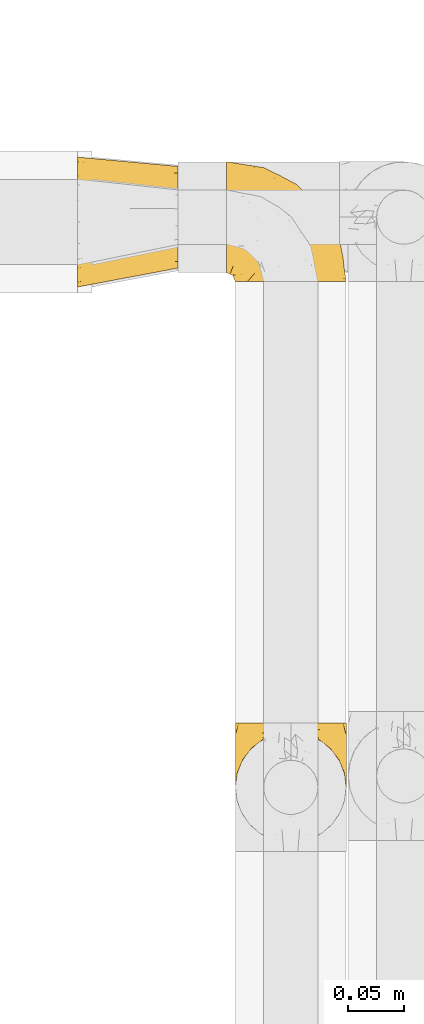
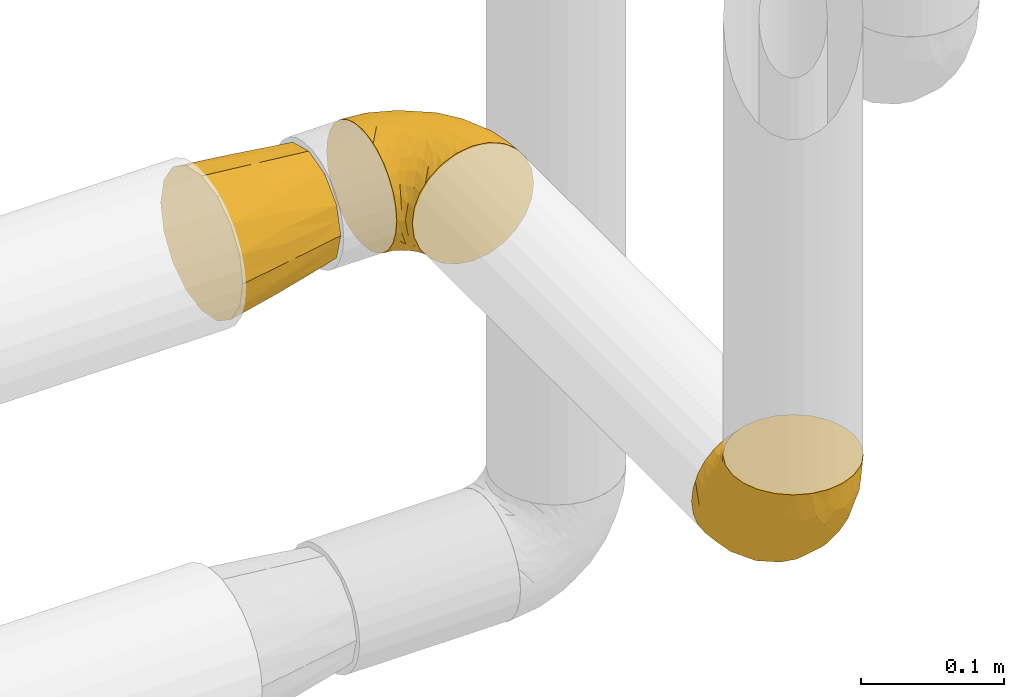
# One storey, part 415 of 824: 3 coverings.
"""IFC2X3 building model written with IfcOpenShell, lengths in millimetres."""

from ifc_helpers import new_model, entity, si_unit, converted_unit, derived_unit, direction, frame, origin, place, context, subcontext, project, spatial, faceted_brep, element, save


model = new_model("IFC2X3")

# Units and contexts
model_context = context("Model", 3, precision=0.01, world=origin(), true_north=direction((6.12303176911189e-17, 1.0)))
body_context = subcontext(model_context, "Body", "Model", "MODEL_VIEW")
ifc_project = project(units=[si_unit("LENGTHUNIT", "METRE", prefix="MILLI"), si_unit("AREAUNIT", "SQUARE_METRE"), si_unit("VOLUMEUNIT", "CUBIC_METRE"), converted_unit("PLANEANGLEUNIT", "DEGREE", entity("IfcRatioMeasure", 0.0174532925199433), si_unit("PLANEANGLEUNIT", "RADIAN"), dimensions=[0, 0, 0, 0, 0, 0, 0]), si_unit("MASSUNIT", "GRAM", prefix="KILO"), derived_unit("MASSDENSITYUNIT", [(si_unit("MASSUNIT", "GRAM", prefix="KILO"), 1), (si_unit("LENGTHUNIT", "METRE"), -3)]), derived_unit("MOMENTOFINERTIAUNIT", [(si_unit("LENGTHUNIT", "METRE"), 4)]), si_unit("TIMEUNIT", "SECOND"), si_unit("FREQUENCYUNIT", "HERTZ"), si_unit("THERMODYNAMICTEMPERATUREUNIT", "DEGREE_CELSIUS"), derived_unit("THERMALTRANSMITTANCEUNIT", [(si_unit("MASSUNIT", "GRAM", prefix="KILO"), 1), (si_unit("THERMODYNAMICTEMPERATUREUNIT", "KELVIN"), -1), (si_unit("TIMEUNIT", "SECOND"), -3)]), derived_unit("VOLUMETRICFLOWRATEUNIT", [(si_unit("LENGTHUNIT", "METRE"), 3), (si_unit("TIMEUNIT", "SECOND"), -1)]), derived_unit("MASSFLOWRATEUNIT", [(si_unit("MASSUNIT", "GRAM", prefix="KILO"), 1), (si_unit("TIMEUNIT", "SECOND"), -1)]), derived_unit("ROTATIONALFREQUENCYUNIT", [(si_unit("TIMEUNIT", "SECOND"), -1)]), si_unit("ELECTRICCURRENTUNIT", "AMPERE"), si_unit("ELECTRICVOLTAGEUNIT", "VOLT"), si_unit("POWERUNIT", "WATT"), si_unit("FORCEUNIT", "NEWTON", prefix="KILO"), si_unit("ILLUMINANCEUNIT", "LUX"), si_unit("LUMINOUSFLUXUNIT", "LUMEN"), si_unit("LUMINOUSINTENSITYUNIT", "CANDELA"), derived_unit("USERDEFINED", [(si_unit("MASSUNIT", "GRAM", prefix="KILO"), -1), (si_unit("LENGTHUNIT", "METRE"), -2), (si_unit("TIMEUNIT", "SECOND"), 3), (si_unit("LUMINOUSFLUXUNIT", "LUMEN"), 1)]), derived_unit("LINEARVELOCITYUNIT", [(si_unit("LENGTHUNIT", "METRE"), 1), (si_unit("TIMEUNIT", "SECOND"), -1)]), si_unit("PRESSUREUNIT", "PASCAL"), derived_unit("USERDEFINED", [(si_unit("LENGTHUNIT", "METRE"), -2), (si_unit("MASSUNIT", "GRAM", prefix="KILO"), 1), (si_unit("TIMEUNIT", "SECOND"), -2)]), derived_unit("LINEARFORCEUNIT", [(si_unit("MASSUNIT", "GRAM", prefix="KILO"), 1), (si_unit("LENGTHUNIT", "METRE"), 1), (si_unit("TIMEUNIT", "SECOND"), -2), (si_unit("LENGTHUNIT", "METRE"), -1)]), derived_unit("PLANARFORCEUNIT", [(si_unit("MASSUNIT", "GRAM", prefix="KILO"), 1), (si_unit("LENGTHUNIT", "METRE"), 1), (si_unit("TIMEUNIT", "SECOND"), -2), (si_unit("LENGTHUNIT", "METRE"), -2)])], contexts=[model_context])

# Site, building, storey
site_placement = place(None, origin())
site = spatial("IfcSite", under=ifc_project, at=site_placement, CompositionType="ELEMENT")
building_placement = place(site_placement, origin())
building = spatial("IfcBuilding", under=site, at=building_placement, CompositionType="ELEMENT")
storey_placement = place(building_placement, frame((0.0, 0.0, 28200.0)))
storey = spatial("IfcBuildingStorey", under=building, at=storey_placement, CompositionType="ELEMENT", Elevation=28200.0)

# Coverings
covering_1_placement = place(storey_placement, frame((50221.29, 18589.78, 1599.25)))
element("IfcCovering", 1, at=covering_1_placement, inside=storey, PredefinedType="INSULATION", context=body_context, shape_type="Brep", body=[
    faceted_brep([(99.9, 107.75, 50.75), (98.66, 107.75, 39.8), (95.02, 107.75, 29.41), (89.17, 107.75, 20.09), (81.38, 107.75, 12.31), (72.06, 107.75, 6.46), (61.68, 107.75, 2.83), (50.75, 107.75, 1.6), (39.8, 107.75, 2.83), (29.41, 107.75, 6.47), (20.09, 107.75, 12.32), (12.31, 107.75, 20.11), (6.46, 107.75, 29.43), (2.83, 107.75, 39.81), (1.6, 107.75, 50.75), (2.24, 107.75, 56.45), (2.83, 107.75, 61.69), (4.65, 107.75, 66.88), (6.47, 107.75, 72.08), (12.32, 107.75, 81.4), (20.11, 107.75, 89.18), (29.43, 107.75, 95.03), (39.81, 107.75, 98.66), (50.75, 107.75, 99.9), (61.69, 107.75, 98.66), (72.08, 107.75, 95.02), (81.4, 107.75, 89.17), (89.18, 107.75, 81.38), (95.03, 107.75, 72.06), (96.85, 107.75, 66.87), (98.66, 107.75, 61.68), (99.25, 107.75, 56.45), (99.57, 107.75, 53.6), (38.02, 98.22, 107.75), (26.17, 93.31, 107.75), (21.08, 89.4, 107.75), (15.99, 85.5, 107.75), (12.09, 80.41, 107.75), (8.18, 75.32, 107.75), (5.73, 69.39, 107.75), (3.27, 63.47, 107.75), (2.35, 56.48, 107.75), (1.97, 53.61, 107.75), (1.6, 50.75, 107.75), (3.27, 38.02, 107.75), (8.18, 26.17, 107.75), (15.99, 15.99, 107.75), (26.17, 8.18, 107.75), (38.02, 3.27, 107.75), (50.75, 1.6, 107.75), (63.47, 3.27, 107.75), (75.32, 8.18, 107.75), (85.5, 15.99, 107.75), (93.31, 26.17, 107.75), (98.22, 38.02, 107.75), (99.9, 50.75, 107.75), (99.14, 56.48, 107.75), (98.22, 63.47, 107.75), (95.77, 69.39, 107.75), (93.31, 75.32, 107.75), (89.4, 80.41, 107.75), (85.5, 85.5, 107.75), (80.41, 89.4, 107.75), (75.32, 93.31, 107.75), (63.47, 98.22, 107.75), (50.75, 99.9, 107.75), (59.31, 27.53, 39.38), (73.08, 25.32, 49.75), (63.72, 16.29, 57.38), (50.75, 6.79, 74.94), (58.64, 4.51, 85.97), (50.75, 3.51, 95.66), (76.74, 17.47, 67.82), (67.68, 7.6, 83.09), (78.92, 12.27, 89.16), (94.31, 70.89, 37.01), (98.76, 87.17, 43.46), (98.4, 67.3, 51.79), (94.57, 31.65, 85.58), (89.91, 33.58, 62.84), (96.32, 47.23, 62.77), (98.79, 43.26, 88.17), (99.9, 55.08, 85.93), (99.9, 53.99, 91.42), (99.9, 52.9, 96.91), (99.9, 52.36, 99.62), (99.9, 51.82, 102.33), (87.31, 21.5, 82.57), (95.61, 89.94, 32.75), (60.43, 60.45, 13.79), (65.24, 83.0, 6.77), (72.87, 64.79, 16.46), (99.9, 85.93, 55.08), (99.9, 81.31, 58.17), (99.9, 76.69, 61.26), (99.9, 72.06, 64.35), (99.9, 67.44, 67.44), (90.65, 88.74, 24.18), (63.14, 45.98, 23.37), (91.89, 47.13, 49.76), (75.25, 89.4, 9.84), (50.75, 95.66, 3.51), (82.18, 28.5, 55.75), (85.08, 42.81, 42.34), (76.93, 38.28, 37.78), (50.75, 45.35, 21.87), (50.75, 33.61, 33.61), (83.02, 82.57, 17.1), (99.9, 105.04, 51.28), (99.9, 102.33, 51.82), (99.9, 96.91, 52.9), (99.9, 91.42, 53.99), (87.13, 65.92, 28.01), (80.85, 53.11, 28.99), (99.17, 54.37, 69.9), (50.75, 74.94, 6.79), (99.9, 64.35, 72.06), (99.9, 61.26, 76.69), (99.9, 58.17, 81.31), (50.75, 21.87, 45.35), (67.61, 34.79, 34.79), (72.25, 48.48, 25.72), (50.75, 60.15, 14.33), (50.75, 14.33, 60.15), (98.69, 99.07, 62.38), (99.01, 60.55, 100.57), (98.79, 64.18, 91.06), (98.29, 64.36, 97.66), (68.51, 103.17, 97.55), (76.82, 101.69, 93.65), (98.54, 87.75, 66.85), (99.3, 89.38, 61.93), (83.57, 88.34, 101.4), (89.47, 82.14, 100.07), (75.76, 94.51, 101.36), (84.86, 89.64, 95.94), (75.89, 98.41, 96.3), (64.77, 99.71, 101.98), (90.83, 89.37, 85.88), (94.62, 88.21, 78.88), (90.37, 95.2, 82.8), (91.18, 79.14, 102.58), (88.65, 101.22, 82.88), (84.11, 99.41, 88.57), (91.75, 84.72, 88.67), (96.86, 97.47, 69.08), (50.75, 102.19, 102.19), (58.97, 104.02, 100.06), (98.37, 82.66, 70.56), (83.91, 95.42, 91.07), (97.52, 78.67, 77.56), (95.55, 72.69, 96.59), (98.76, 66.46, 86.38), (95.26, 75.3, 91.79), (98.04, 72.74, 81.71), (90.65, 82.93, 94.11), (93.51, 99.27, 76.09), (94.16, 93.51, 76.91), (99.1, 67.35, 81.44), (25.73, 94.51, 101.37), (10.84, 82.94, 94.12), (17.92, 88.33, 101.41), (16.64, 89.64, 95.96), (30.44, 103.62, 96.22), (2.95, 87.74, 66.85), (2.19, 89.38, 61.94), (1.6, 81.31, 58.17), (4.63, 97.47, 69.1), (17.39, 99.41, 88.58), (1.6, 52.9, 96.91), (1.6, 51.82, 102.33), (1.6, 51.28, 105.04), (12.86, 101.21, 82.9), (11.13, 95.19, 82.82), (3.2, 64.36, 97.66), (5.94, 72.69, 96.59), (10.31, 79.14, 102.58), (8.0, 99.28, 76.13), (7.34, 93.51, 76.93), (2.48, 60.55, 100.57), (2.73, 66.46, 86.38), (2.64, 63.96, 90.86), (1.6, 96.91, 52.9), (2.8, 99.06, 62.39), (36.71, 99.7, 101.98), (1.6, 53.99, 91.42), (1.6, 55.08, 85.93), (38.59, 103.3, 99.49), (1.6, 102.33, 51.82), (1.6, 99.62, 52.36), (1.6, 76.69, 61.26), (3.12, 82.66, 70.56), (17.59, 95.42, 91.09), (1.6, 72.06, 64.35), (3.98, 78.68, 77.6), (6.87, 88.2, 78.89), (3.45, 72.75, 81.71), (9.76, 84.74, 88.69), (1.6, 91.42, 53.99), (1.6, 85.93, 55.08), (25.62, 98.41, 96.31), (10.67, 89.37, 85.9), (2.39, 67.35, 81.45), (1.6, 61.26, 76.69), (6.23, 75.3, 91.79), (12.02, 82.13, 100.07), (1.6, 58.17, 81.31), (1.6, 64.35, 72.06), (1.6, 67.44, 67.44), (2.4, 54.08, 69.6), (42.85, 4.51, 85.97), (14.18, 21.5, 82.57), (11.56, 33.43, 63.16), (19.27, 28.5, 55.81), (24.75, 17.47, 67.81), (28.37, 25.36, 49.73), (5.95, 90.18, 32.55), (2.79, 86.97, 43.23), (2.71, 43.26, 88.17), (37.78, 16.29, 57.38), (33.81, 7.6, 83.08), (22.57, 12.27, 89.16), (6.92, 31.65, 85.58), (28.61, 64.79, 16.46), (36.24, 83.0, 6.77), (41.05, 60.44, 13.8), (24.55, 38.35, 37.71), (33.88, 34.8, 34.8), (7.11, 71.54, 36.83), (42.18, 27.53, 39.38), (18.46, 82.57, 17.12), (10.84, 88.74, 24.19), (20.69, 53.19, 28.89), (29.27, 48.49, 25.69), (3.1, 67.28, 51.77), (9.18, 52.32, 45.66), (38.38, 45.94, 23.39), (26.23, 89.4, 9.85), (14.34, 65.75, 28.11), (5.46, 46.73, 62.27), (16.39, 42.82, 42.35)], [[[0, 1, 2, 3, 4, 5, 6, 7, 8, 9, 10, 11, 12, 13, 14, 15, 16, 17, 18, 19, 20, 21, 22, 23, 24, 25, 26, 27, 28, 29, 30, 31, 32]], [[33, 34, 35, 36, 37, 38, 39, 40, 41, 42, 43, 44, 45, 46, 47, 48, 49, 50, 51, 52, 53, 54, 55, 56, 57, 58, 59, 60, 61, 62, 63, 64, 65]], [[66, 67, 68]], [[69, 70, 71]], [[68, 72, 73]], [[73, 72, 74]], [[75, 76, 77]], [[78, 79, 80]], [[51, 50, 73]], [[81, 82, 83, 84, 85, 86, 55]], [[52, 87, 53]], [[74, 52, 51]], [[2, 1, 88]], [[89, 90, 91]], [[77, 92, 93, 94, 95, 96]], [[55, 54, 81]], [[78, 53, 87]], [[5, 90, 6]], [[88, 76, 75]], [[97, 3, 2]], [[89, 91, 98]], [[99, 80, 79]], [[90, 5, 100]], [[74, 87, 52]], [[100, 5, 4]], [[90, 101, 6]], [[79, 102, 103]], [[102, 67, 104]], [[105, 98, 106]], [[107, 4, 3]], [[76, 0, 108, 109, 110, 111, 92]], [[107, 112, 113]], [[114, 77, 96]], [[89, 115, 90]], [[114, 96, 116, 117, 118, 82]], [[75, 97, 88]], [[119, 66, 68]], [[50, 71, 70]], [[100, 91, 90]], [[99, 77, 80]], [[102, 104, 103]], [[97, 107, 3]], [[80, 81, 78]], [[107, 97, 112]], [[68, 73, 70]], [[66, 98, 120]], [[78, 81, 54]], [[114, 81, 80]], [[53, 78, 54]], [[78, 87, 79]], [[102, 87, 72]], [[79, 103, 99]], [[4, 107, 100]], [[91, 100, 107]], [[88, 97, 2]], [[112, 97, 75]], [[99, 112, 75]], [[103, 104, 113]], [[91, 121, 98]], [[89, 105, 122, 115]], [[101, 90, 115]], [[101, 7, 6]], [[88, 1, 76]], [[0, 76, 1]], [[92, 77, 76]], [[73, 74, 51]], [[87, 74, 72]], [[81, 114, 82]], [[77, 114, 80]], [[87, 102, 79]], [[67, 102, 72]], [[68, 67, 72]], [[67, 120, 104]], [[120, 121, 104]], [[104, 121, 113]], [[121, 120, 98]], [[91, 107, 113]], [[91, 113, 121]], [[103, 113, 112]], [[66, 119, 106]], [[105, 89, 98]], [[68, 69, 123, 119]], [[67, 66, 120]], [[98, 66, 106]], [[50, 49, 71]], [[50, 70, 73]], [[112, 99, 103]], [[77, 99, 75]], [[69, 68, 70]], [[29, 124, 110]], [[84, 83, 125]], [[126, 82, 118]], [[59, 58, 127]], [[25, 128, 129]], [[130, 93, 131]], [[132, 62, 133]], [[134, 135, 136]], [[137, 65, 64]], [[64, 134, 137]], [[138, 139, 140]], [[111, 110, 124, 92]], [[134, 136, 137]], [[134, 64, 63]], [[133, 61, 141]], [[125, 58, 57]], [[142, 143, 140]], [[142, 26, 143]], [[127, 83, 82]], [[28, 124, 29]], [[108, 0, 32, 31, 30, 110, 109]], [[30, 29, 110]], [[135, 144, 138]], [[28, 145, 124]], [[57, 56, 55, 86, 85, 84]], [[146, 147, 23]], [[24, 23, 147]], [[25, 143, 26]], [[95, 94, 148]], [[24, 128, 25]], [[149, 138, 143]], [[124, 145, 131]], [[127, 58, 125]], [[150, 148, 139]], [[127, 126, 151]], [[151, 59, 127]], [[152, 151, 126]], [[153, 154, 155]], [[153, 133, 141]], [[145, 28, 27]], [[142, 156, 27]], [[157, 148, 130]], [[61, 133, 62]], [[134, 132, 135]], [[147, 128, 24]], [[65, 137, 146]], [[146, 137, 147]], [[128, 137, 136]], [[137, 128, 147]], [[128, 136, 129]], [[149, 129, 136]], [[25, 129, 143]], [[158, 152, 117]], [[152, 118, 117]], [[153, 151, 152]], [[158, 116, 154]], [[144, 150, 138]], [[153, 152, 158]], [[133, 153, 155]], [[133, 155, 132]], [[141, 61, 60]], [[135, 132, 155]], [[134, 63, 132]], [[144, 135, 155]], [[135, 138, 149]], [[155, 154, 144]], [[150, 154, 96]], [[154, 150, 144]], [[148, 94, 130]], [[82, 126, 127]], [[118, 152, 126]], [[150, 96, 95]], [[139, 148, 157]], [[150, 95, 148]], [[93, 92, 131]], [[130, 145, 156]], [[130, 94, 93]], [[84, 125, 57]], [[127, 125, 83]], [[140, 139, 157]], [[150, 139, 138]], [[140, 157, 142]], [[138, 140, 143]], [[156, 142, 157]], [[27, 26, 142]], [[130, 156, 157]], [[145, 27, 156]], [[132, 63, 62]], [[124, 131, 92]], [[130, 131, 145]], [[129, 149, 143]], [[135, 149, 136]], [[60, 151, 141]], [[59, 151, 60]], [[141, 151, 153]], [[116, 96, 154]], [[153, 158, 154]], [[158, 117, 116]], [[34, 33, 159]], [[160, 161, 162]], [[22, 21, 163]], [[164, 165, 166]], [[19, 18, 167]], [[168, 21, 20]], [[42, 41, 40, 169, 170, 171, 43]], [[172, 173, 168]], [[174, 38, 175]], [[176, 37, 36]], [[177, 164, 178]], [[40, 179, 169]], [[180, 181, 175]], [[17, 182, 183]], [[65, 146, 184]], [[185, 174, 186]], [[23, 22, 187]], [[174, 39, 38]], [[15, 14, 188, 189, 182, 16]], [[179, 40, 39]], [[190, 191, 164]], [[192, 163, 168]], [[33, 184, 159]], [[178, 173, 172]], [[193, 194, 191]], [[18, 183, 167]], [[173, 178, 195]], [[196, 197, 194]], [[198, 199, 183, 182]], [[182, 17, 16]], [[18, 17, 183]], [[200, 159, 184]], [[192, 168, 201]], [[187, 163, 200]], [[202, 203, 180]], [[185, 179, 174]], [[160, 204, 205]], [[206, 181, 180]], [[206, 180, 203]], [[199, 165, 183]], [[165, 164, 167]], [[172, 177, 178]], [[200, 192, 162]], [[205, 161, 160]], [[65, 184, 33]], [[163, 187, 22]], [[175, 204, 180]], [[174, 181, 186]], [[204, 196, 202]], [[197, 160, 162]], [[196, 207, 202]], [[205, 204, 176]], [[196, 204, 160]], [[176, 204, 175]], [[205, 35, 161]], [[34, 159, 161]], [[162, 161, 159]], [[200, 162, 159]], [[197, 162, 201]], [[194, 197, 201]], [[196, 160, 197]], [[191, 195, 178]], [[208, 196, 194]], [[186, 181, 206]], [[175, 181, 174]], [[191, 190, 193]], [[193, 208, 194]], [[195, 194, 201]], [[178, 164, 191]], [[168, 163, 21]], [[166, 165, 199]], [[166, 190, 164]], [[187, 200, 184]], [[184, 146, 187]], [[23, 187, 146]], [[174, 179, 39]], [[169, 179, 185]], [[194, 195, 191]], [[173, 201, 168]], [[201, 173, 195]], [[172, 168, 20]], [[20, 19, 172]], [[177, 172, 19]], [[19, 167, 177]], [[164, 177, 167]], [[35, 205, 36]], [[35, 34, 161]], [[183, 165, 167]], [[162, 192, 201]], [[163, 192, 200]], [[175, 38, 37]], [[205, 176, 36]], [[175, 37, 176]], [[204, 202, 180]], [[207, 196, 208]], [[207, 203, 202]], [[209, 186, 206, 203, 207, 208]], [[48, 210, 71]], [[211, 212, 213]], [[214, 213, 215]], [[216, 217, 13]], [[218, 43, 171, 170, 169, 185, 186]], [[219, 220, 214]], [[47, 46, 221]], [[210, 48, 220]], [[211, 222, 212]], [[222, 45, 44]], [[221, 220, 47]], [[47, 220, 48]], [[221, 211, 214]], [[223, 224, 225]], [[211, 46, 45]], [[226, 227, 215]], [[43, 218, 44]], [[217, 216, 228]], [[219, 215, 229]], [[14, 13, 217]], [[224, 9, 8]], [[10, 230, 11]], [[11, 231, 12]], [[232, 223, 233]], [[234, 208, 193, 190, 166, 199]], [[235, 234, 228]], [[222, 44, 218]], [[106, 229, 236]], [[224, 237, 9]], [[231, 238, 228]], [[9, 237, 10]], [[115, 224, 101]], [[239, 234, 235]], [[231, 11, 230]], [[223, 230, 237]], [[224, 8, 101]], [[223, 236, 233]], [[225, 115, 122, 105]], [[216, 12, 231]], [[209, 234, 239]], [[210, 219, 69]], [[219, 214, 215]], [[229, 119, 219]], [[209, 218, 186]], [[239, 212, 222]], [[239, 222, 218]], [[45, 222, 211]], [[235, 212, 239]], [[213, 212, 240]], [[223, 237, 224]], [[230, 10, 237]], [[238, 231, 230]], [[216, 231, 228]], [[232, 230, 223]], [[235, 238, 240]], [[115, 225, 224]], [[233, 236, 227]], [[8, 7, 101]], [[234, 209, 208]], [[218, 209, 239]], [[217, 228, 234]], [[13, 12, 216]], [[234, 199, 217]], [[217, 199, 198, 182, 189, 188, 14]], [[211, 221, 46]], [[220, 221, 214]], [[71, 210, 69]], [[71, 49, 48]], [[219, 210, 220]], [[226, 215, 213]], [[211, 213, 214]], [[226, 213, 240]], [[215, 227, 229]], [[232, 240, 238]], [[233, 227, 226]], [[232, 233, 226]], [[236, 223, 225]], [[240, 232, 226]], [[232, 238, 230]], [[225, 105, 236]], [[236, 105, 106]], [[236, 229, 227]], [[123, 69, 219, 119]], [[106, 119, 229]], [[238, 235, 228]], [[212, 235, 240]]]),
])
covering_2_placement = place(storey_placement, frame((50213.44, 19086.93, 1599.25)))
element("IfcCovering", 2, at=covering_2_placement, inside=storey, PredefinedType="INSULATION", context=body_context, shape_type="Brep", body=[
    faceted_brep([(1.6, 58.6, 99.9), (1.6, 69.54, 98.66), (1.6, 79.93, 95.02), (1.6, 89.25, 89.17), (1.6, 97.03, 81.38), (1.6, 102.88, 72.06), (1.6, 106.51, 61.68), (1.6, 107.75, 50.75), (1.6, 106.51, 39.8), (1.6, 102.87, 29.41), (1.6, 97.02, 20.09), (1.6, 89.23, 12.31), (1.6, 79.91, 6.46), (1.6, 69.53, 2.83), (1.6, 58.6, 1.6), (1.6, 52.89, 2.24), (1.6, 47.65, 2.83), (1.6, 42.46, 4.65), (1.6, 37.26, 6.47), (1.6, 27.94, 12.32), (1.6, 20.16, 20.11), (1.6, 14.31, 29.43), (1.6, 10.68, 39.81), (1.6, 9.45, 50.75), (1.6, 10.68, 61.69), (1.6, 14.32, 72.08), (1.6, 20.17, 81.4), (1.6, 27.96, 89.18), (1.6, 37.28, 95.03), (1.6, 42.47, 96.85), (1.6, 47.66, 98.66), (1.6, 52.89, 99.25), (1.6, 55.75, 99.57), (11.12, 1.6, 38.02), (16.03, 1.6, 26.17), (19.94, 1.6, 21.08), (23.84, 1.6, 15.99), (28.93, 1.6, 12.09), (34.02, 1.6, 8.18), (39.95, 1.6, 5.73), (45.87, 1.6, 3.27), (52.86, 1.6, 2.35), (55.73, 1.6, 1.97), (58.6, 1.6, 1.6), (71.32, 1.6, 3.27), (83.17, 1.6, 8.18), (93.35, 1.6, 15.99), (101.16, 1.6, 26.17), (106.07, 1.6, 38.02), (107.75, 1.6, 50.75), (106.07, 1.6, 63.47), (101.16, 1.6, 75.32), (93.35, 1.6, 85.5), (83.17, 1.6, 93.31), (71.32, 1.6, 98.22), (58.6, 1.6, 99.9), (52.86, 1.6, 99.14), (45.87, 1.6, 98.22), (39.95, 1.6, 95.77), (34.02, 1.6, 93.31), (28.93, 1.6, 89.4), (23.84, 1.6, 85.5), (19.94, 1.6, 80.41), (16.03, 1.6, 75.32), (11.12, 1.6, 63.47), (9.45, 1.6, 50.75), (81.82, 69.96, 59.31), (84.02, 59.59, 73.08), (93.05, 51.96, 63.72), (102.55, 34.4, 50.75), (104.83, 23.37, 58.64), (105.83, 13.68, 50.75), (91.87, 41.52, 76.74), (101.74, 26.26, 67.68), (97.07, 20.18, 78.92), (38.45, 72.33, 94.31), (22.17, 65.88, 98.76), (42.04, 57.55, 98.4), (77.69, 23.76, 94.57), (75.76, 46.5, 89.91), (62.11, 46.57, 96.32), (66.08, 21.17, 98.79), (54.26, 23.41, 99.9), (55.35, 17.92, 99.9), (56.44, 12.43, 99.9), (56.98, 9.72, 99.9), (57.52, 7.01, 99.9), (87.84, 26.77, 87.31), (19.41, 76.59, 95.61), (48.89, 95.55, 60.43), (26.34, 102.57, 65.24), (44.55, 92.89, 72.87), (23.41, 54.26, 99.9), (28.03, 51.17, 99.9), (32.65, 48.08, 99.9), (37.28, 44.99, 99.9), (41.9, 41.9, 99.9), (20.6, 85.16, 90.65), (63.36, 85.97, 63.14), (62.21, 59.58, 91.89), (19.94, 99.5, 75.25), (13.68, 105.83, 50.75), (80.85, 53.59, 82.18), (66.53, 67.0, 85.08), (71.06, 71.56, 76.93), (63.99, 87.47, 50.75), (75.73, 75.73, 50.75), (26.77, 92.24, 83.02), (4.31, 58.06, 99.9), (7.01, 57.52, 99.9), (12.43, 56.44, 99.9), (17.92, 55.35, 99.9), (43.43, 81.33, 87.13), (56.23, 80.35, 80.85), (54.97, 39.44, 99.17), (34.4, 102.55, 50.75), (44.99, 37.28, 99.9), (48.08, 32.65, 99.9), (51.17, 28.03, 99.9), (87.47, 63.99, 50.75), (74.55, 74.55, 67.61), (60.86, 83.62, 72.25), (49.19, 95.01, 50.75), (95.01, 49.19, 50.75), (10.27, 46.96, 98.69), (48.79, 8.77, 99.01), (45.16, 18.28, 98.79), (44.99, 11.68, 98.29), (6.17, 11.79, 68.51), (7.65, 15.69, 76.82), (21.59, 42.49, 98.54), (19.96, 47.41, 99.3), (21.0, 7.94, 83.57), (27.2, 9.27, 89.47), (14.83, 7.98, 75.76), (19.7, 13.4, 84.86), (10.93, 13.04, 75.89), (9.63, 7.36, 64.77), (19.97, 23.46, 90.83), (21.13, 30.46, 94.62), (14.14, 26.54, 90.37), (30.2, 6.76, 91.18), (36.65, 12.75, 95.55), (8.12, 26.46, 88.65), (9.93, 20.77, 84.11), (24.62, 20.68, 91.75), (11.87, 40.26, 96.86), (7.15, 7.15, 50.75), (5.32, 9.28, 58.97), (26.68, 38.78, 98.37), (13.92, 18.27, 83.91), (30.67, 31.78, 97.52), (42.89, 22.96, 98.76), (34.04, 17.55, 95.26), (36.6, 27.63, 98.04), (26.41, 15.23, 90.65), (10.07, 33.25, 93.51), (15.83, 32.43, 94.16), (41.99, 27.9, 99.1), (14.83, 7.97, 25.73), (26.4, 15.22, 10.84), (21.01, 7.93, 17.92), (19.71, 13.38, 16.64), (5.72, 13.12, 30.44), (21.6, 42.49, 2.95), (19.96, 47.4, 2.19), (28.03, 51.17, 1.6), (11.87, 40.24, 4.63), (9.93, 20.76, 17.39), (56.44, 12.43, 1.6), (57.52, 7.01, 1.6), (58.06, 4.31, 1.6), (8.13, 26.44, 12.86), (14.15, 26.52, 11.13), (44.99, 11.68, 3.2), (36.65, 12.75, 5.94), (27.21, 9.27, 12.02), (34.04, 17.55, 6.23), (30.2, 6.76, 10.31), (10.06, 33.21, 8.0), (15.83, 32.41, 7.34), (48.79, 8.77, 2.48), (42.89, 22.96, 2.73), (45.38, 18.48, 2.64), (12.43, 56.44, 1.6), (10.28, 46.95, 2.8), (9.64, 7.36, 36.71), (55.35, 17.92, 1.6), (54.26, 23.41, 1.6), (6.05, 9.85, 38.59), (7.01, 57.52, 1.6), (9.72, 56.98, 1.6), (32.65, 48.08, 1.6), (26.68, 38.78, 3.12), (13.92, 18.25, 17.59), (37.28, 44.99, 1.6), (30.66, 31.74, 3.98), (21.14, 30.45, 6.87), (36.59, 27.63, 3.45), (24.6, 20.65, 9.76), (17.92, 55.35, 1.6), (23.41, 54.26, 1.6), (10.93, 13.03, 25.62), (19.97, 23.44, 10.67), (41.99, 27.9, 2.39), (48.08, 32.65, 1.6), (51.17, 28.03, 1.6), (44.99, 37.28, 1.6), (41.9, 41.9, 1.6), (55.26, 39.74, 2.4), (104.83, 23.37, 42.85), (87.84, 26.77, 14.18), (75.91, 46.18, 11.56), (80.84, 53.54, 19.27), (91.87, 41.53, 24.75), (83.98, 59.61, 28.37), (19.16, 76.79, 5.95), (22.37, 66.11, 2.79), (66.08, 21.17, 2.71), (93.05, 51.96, 37.78), (101.74, 26.26, 33.81), (97.07, 20.18, 22.57), (77.69, 23.76, 6.92), (44.55, 92.88, 28.61), (26.34, 102.57, 36.24), (48.9, 95.54, 41.05), (70.99, 71.63, 24.55), (74.55, 74.55, 33.88), (37.8, 72.51, 7.11), (63.4, 85.95, 38.38), (81.82, 69.96, 42.18), (26.77, 92.23, 18.46), (20.6, 85.15, 10.84), (56.15, 80.45, 20.69), (60.85, 83.65, 29.27), (42.06, 57.57, 3.1), (57.03, 63.68, 9.18), (19.94, 99.49, 26.23), (43.59, 81.23, 14.34), (62.61, 47.07, 5.46), (66.52, 66.99, 16.39)], [[[0, 1, 2, 3, 4, 5, 6, 7, 8, 9, 10, 11, 12, 13, 14, 15, 16, 17, 18, 19, 20, 21, 22, 23, 24, 25, 26, 27, 28, 29, 30, 31, 32]], [[33, 34, 35, 36, 37, 38, 39, 40, 41, 42, 43, 44, 45, 46, 47, 48, 49, 50, 51, 52, 53, 54, 55, 56, 57, 58, 59, 60, 61, 62, 63, 64, 65]], [[66, 67, 68]], [[69, 70, 71]], [[68, 72, 73]], [[73, 72, 74]], [[75, 76, 77]], [[78, 79, 80]], [[51, 50, 73]], [[81, 82, 83, 84, 85, 86, 55]], [[52, 87, 53]], [[74, 52, 51]], [[2, 1, 88]], [[89, 90, 91]], [[77, 92, 93, 94, 95, 96]], [[55, 54, 81]], [[78, 53, 87]], [[5, 90, 6]], [[88, 76, 75]], [[97, 3, 2]], [[89, 91, 98]], [[99, 80, 79]], [[90, 5, 100]], [[74, 87, 52]], [[100, 5, 4]], [[90, 101, 6]], [[79, 102, 103]], [[102, 67, 104]], [[105, 98, 106]], [[107, 4, 3]], [[76, 0, 108, 109, 110, 111, 92]], [[107, 112, 113]], [[114, 77, 96]], [[89, 115, 90]], [[114, 96, 116, 117, 118, 82]], [[75, 97, 88]], [[119, 66, 68]], [[50, 71, 70]], [[100, 91, 90]], [[99, 77, 80]], [[102, 104, 103]], [[97, 107, 3]], [[80, 81, 78]], [[107, 97, 112]], [[68, 73, 70]], [[66, 98, 120]], [[78, 81, 54]], [[114, 81, 80]], [[53, 78, 54]], [[78, 87, 79]], [[102, 87, 72]], [[79, 103, 99]], [[4, 107, 100]], [[91, 100, 107]], [[88, 97, 2]], [[112, 97, 75]], [[99, 112, 75]], [[103, 104, 113]], [[91, 121, 98]], [[89, 105, 122, 115]], [[101, 90, 115]], [[101, 7, 6]], [[88, 1, 76]], [[0, 76, 1]], [[92, 77, 76]], [[73, 74, 51]], [[87, 74, 72]], [[81, 114, 82]], [[77, 114, 80]], [[87, 102, 79]], [[67, 102, 72]], [[68, 67, 72]], [[67, 120, 104]], [[120, 121, 104]], [[104, 121, 113]], [[121, 120, 98]], [[91, 107, 113]], [[91, 113, 121]], [[103, 113, 112]], [[106, 98, 66]], [[105, 89, 98]], [[106, 66, 119]], [[67, 66, 120]], [[68, 69, 123, 119]], [[50, 49, 71]], [[50, 70, 73]], [[112, 99, 103]], [[77, 99, 75]], [[69, 68, 70]], [[29, 124, 110]], [[84, 83, 125]], [[126, 82, 118]], [[59, 58, 127]], [[25, 128, 129]], [[130, 93, 131]], [[132, 62, 133]], [[134, 135, 136]], [[137, 65, 64]], [[64, 134, 137]], [[138, 139, 140]], [[111, 110, 124, 92]], [[134, 136, 137]], [[134, 64, 63]], [[141, 60, 142]], [[125, 58, 57]], [[143, 144, 140]], [[143, 26, 144]], [[127, 83, 82]], [[28, 124, 29]], [[108, 0, 32, 31, 30, 110, 109]], [[30, 29, 110]], [[135, 145, 138]], [[28, 146, 124]], [[57, 56, 55, 86, 85, 84]], [[147, 148, 23]], [[24, 23, 148]], [[25, 144, 26]], [[95, 94, 149]], [[24, 128, 25]], [[150, 138, 144]], [[124, 146, 131]], [[127, 58, 125]], [[151, 149, 139]], [[127, 126, 142]], [[142, 59, 127]], [[152, 142, 126]], [[153, 154, 155]], [[153, 133, 141]], [[146, 28, 27]], [[143, 156, 27]], [[157, 149, 130]], [[61, 133, 62]], [[134, 132, 135]], [[148, 128, 24]], [[65, 137, 147]], [[147, 137, 148]], [[128, 137, 136]], [[137, 128, 148]], [[128, 136, 129]], [[150, 129, 136]], [[25, 129, 144]], [[158, 152, 117]], [[152, 118, 117]], [[153, 142, 152]], [[158, 116, 154]], [[145, 151, 138]], [[153, 152, 158]], [[133, 153, 155]], [[133, 155, 132]], [[153, 141, 142]], [[135, 132, 155]], [[134, 63, 132]], [[145, 135, 155]], [[135, 138, 150]], [[155, 154, 145]], [[151, 154, 96]], [[154, 151, 145]], [[149, 94, 130]], [[82, 126, 127]], [[118, 152, 126]], [[151, 96, 95]], [[139, 149, 157]], [[151, 95, 149]], [[93, 92, 131]], [[130, 146, 156]], [[130, 94, 93]], [[84, 125, 57]], [[127, 125, 83]], [[140, 139, 157]], [[151, 139, 138]], [[140, 157, 143]], [[138, 140, 144]], [[156, 143, 157]], [[27, 26, 143]], [[130, 156, 157]], [[146, 27, 156]], [[132, 63, 62]], [[124, 131, 92]], [[130, 131, 146]], [[129, 150, 144]], [[135, 150, 136]], [[60, 141, 61]], [[60, 59, 142]], [[133, 61, 141]], [[116, 96, 154]], [[153, 158, 154]], [[158, 117, 116]], [[34, 33, 159]], [[160, 161, 162]], [[22, 21, 163]], [[164, 165, 166]], [[19, 18, 167]], [[168, 21, 20]], [[42, 41, 40, 169, 170, 171, 43]], [[172, 173, 168]], [[174, 38, 175]], [[176, 177, 178]], [[179, 164, 180]], [[40, 181, 169]], [[182, 183, 175]], [[17, 184, 185]], [[65, 147, 186]], [[187, 174, 188]], [[23, 22, 189]], [[174, 39, 38]], [[15, 14, 190, 191, 184, 16]], [[181, 40, 39]], [[192, 193, 164]], [[194, 163, 168]], [[33, 186, 159]], [[180, 173, 172]], [[195, 196, 193]], [[18, 185, 167]], [[173, 180, 197]], [[198, 199, 196]], [[200, 201, 185, 184]], [[184, 17, 16]], [[18, 17, 185]], [[202, 159, 186]], [[194, 168, 203]], [[189, 163, 202]], [[204, 205, 182]], [[187, 181, 174]], [[160, 177, 176]], [[206, 183, 182]], [[206, 182, 205]], [[201, 165, 185]], [[165, 164, 167]], [[172, 179, 180]], [[202, 194, 162]], [[176, 161, 160]], [[65, 186, 33]], [[163, 189, 22]], [[175, 177, 182]], [[174, 183, 188]], [[177, 198, 204]], [[199, 160, 162]], [[198, 207, 204]], [[175, 38, 37]], [[198, 177, 160]], [[178, 177, 175]], [[176, 35, 161]], [[34, 159, 161]], [[162, 161, 159]], [[202, 162, 159]], [[199, 162, 203]], [[196, 199, 203]], [[198, 160, 199]], [[193, 197, 180]], [[208, 198, 196]], [[188, 183, 206]], [[175, 183, 174]], [[193, 192, 195]], [[195, 208, 196]], [[197, 196, 203]], [[180, 164, 193]], [[168, 163, 21]], [[166, 165, 201]], [[166, 192, 164]], [[189, 202, 186]], [[186, 147, 189]], [[23, 189, 147]], [[174, 181, 39]], [[169, 181, 187]], [[196, 197, 193]], [[173, 203, 168]], [[203, 173, 197]], [[172, 168, 20]], [[20, 19, 172]], [[179, 172, 19]], [[19, 167, 179]], [[164, 179, 167]], [[35, 176, 36]], [[35, 34, 161]], [[185, 165, 167]], [[162, 194, 203]], [[163, 194, 202]], [[176, 178, 36]], [[37, 36, 178]], [[175, 37, 178]], [[177, 204, 182]], [[207, 198, 208]], [[207, 205, 204]], [[209, 188, 206, 205, 207, 208]], [[48, 210, 71]], [[211, 212, 213]], [[214, 213, 215]], [[216, 217, 13]], [[218, 43, 171, 170, 169, 187, 188]], [[219, 220, 214]], [[47, 46, 221]], [[210, 48, 220]], [[211, 222, 212]], [[222, 45, 44]], [[221, 220, 47]], [[47, 220, 48]], [[221, 211, 214]], [[223, 224, 225]], [[211, 46, 45]], [[226, 227, 215]], [[43, 218, 44]], [[217, 216, 228]], [[227, 229, 230]], [[14, 13, 217]], [[224, 9, 8]], [[10, 231, 11]], [[11, 232, 12]], [[233, 223, 234]], [[235, 208, 195, 192, 166, 201]], [[236, 235, 228]], [[222, 44, 218]], [[106, 230, 229]], [[224, 237, 9]], [[232, 238, 228]], [[9, 237, 10]], [[115, 224, 101]], [[239, 235, 236]], [[232, 11, 231]], [[223, 231, 237]], [[224, 8, 101]], [[223, 229, 234]], [[225, 115, 122, 105]], [[216, 12, 232]], [[209, 235, 239]], [[210, 219, 69]], [[219, 214, 215]], [[230, 119, 219]], [[209, 218, 188]], [[239, 212, 222]], [[239, 222, 218]], [[45, 222, 211]], [[236, 212, 239]], [[213, 212, 240]], [[223, 237, 224]], [[231, 10, 237]], [[238, 232, 231]], [[216, 232, 228]], [[233, 231, 223]], [[236, 238, 240]], [[115, 225, 224]], [[234, 229, 227]], [[8, 7, 101]], [[235, 209, 208]], [[218, 209, 239]], [[217, 228, 235]], [[13, 12, 216]], [[235, 201, 217]], [[217, 201, 200, 184, 191, 190, 14]], [[211, 221, 46]], [[220, 221, 214]], [[71, 210, 69]], [[71, 49, 48]], [[219, 210, 220]], [[226, 215, 213]], [[211, 213, 214]], [[226, 213, 240]], [[215, 227, 230]], [[233, 240, 238]], [[234, 227, 226]], [[233, 234, 226]], [[229, 223, 225]], [[240, 233, 226]], [[233, 238, 231]], [[225, 105, 229]], [[229, 105, 106]], [[106, 119, 230]], [[123, 69, 219, 119]], [[215, 230, 219]], [[238, 236, 228]], [[212, 236, 240]]]),
])
covering_3_placement = place(storey_placement, frame((50083.3, 19082.13, 1590.9)))
element("IfcCovering", 3, at=covering_3_placement, inside=storey, PredefinedType="INSULATION", context=body_context, shape_type="Brep", body=[
    faceted_brep([(0.0, 99.75, 99.75), (0.0, 105.99, 90.43), (0.0, 112.22, 81.1), (0.0, 114.41, 70.1), (0.0, 116.6, 59.1), (0.0, 114.55, 48.79), (0.0, 112.22, 37.09), (0.0, 105.99, 27.76), (0.0, 99.75, 18.44), (0.0, 90.43, 12.2), (0.0, 81.1, 5.97), (0.0, 70.1, 3.78), (0.0, 59.1, 1.6), (0.0, 48.84, 3.63), (0.0, 37.09, 5.97), (0.0, 27.76, 12.2), (0.0, 18.44, 18.44), (0.0, 12.2, 27.76), (0.0, 5.97, 37.09), (0.0, 3.78, 48.09), (0.0, 1.6, 59.1), (0.0, 3.63, 69.35), (0.0, 5.97, 81.1), (0.0, 12.2, 90.43), (0.0, 18.44, 99.75), (0.0, 27.76, 105.99), (0.0, 37.09, 112.22), (0.0, 48.09, 114.41), (0.0, 59.1, 116.6), (0.0, 69.4, 114.55), (0.0, 81.1, 112.22), (0.0, 90.43, 105.99), (89.0, 32.67, 89.83), (89.0, 24.43, 81.6), (89.0, 21.42, 70.35), (89.0, 18.4, 59.1), (89.0, 21.42, 47.85), (89.0, 24.43, 36.6), (89.0, 32.67, 28.36), (89.0, 40.9, 20.12), (89.0, 52.15, 17.11), (89.0, 63.4, 14.1), (89.0, 74.65, 17.11), (89.0, 85.9, 20.12), (89.0, 94.14, 28.36), (89.0, 102.37, 36.6), (89.0, 105.39, 47.85), (89.0, 108.4, 59.1), (89.0, 105.39, 70.35), (89.0, 102.37, 81.6), (89.0, 94.14, 89.83), (89.0, 85.9, 98.07), (89.0, 74.65, 101.08), (89.0, 63.4, 104.1), (89.0, 52.15, 101.08), (89.0, 40.9, 98.07), (46.81, 112.29, 59.1), (41.48, 110.64, 44.4), (41.49, 106.52, 34.46), (42.19, 112.71, 59.1), (44.5, 92.45, 18.44), (43.62, 74.0, 9.34), (44.5, 100.21, 25.8), (45.16, 83.52, 13.02), (42.19, 61.14, 7.52), (47.01, 61.37, 8.2), (41.45, 46.43, 9.54), (41.53, 36.49, 13.67), (44.5, 20.59, 27.9), (43.62, 11.45, 46.3), (44.5, 27.95, 20.14), (45.16, 15.21, 36.86), (41.99, 9.53, 59.1), (47.01, 10.47, 59.1), (41.45, 11.55, 73.77), (41.53, 15.68, 83.71), (44.5, 30.05, 99.75), (43.62, 48.41, 108.85), (44.5, 22.29, 92.39), (45.16, 39.04, 105.17), (41.99, 61.13, 110.7), (46.81, 61.36, 110.02), (41.48, 75.79, 108.64), (41.49, 85.74, 104.52), (44.5, 101.91, 90.29), (43.62, 110.96, 71.89), (44.5, 94.55, 98.05), (45.16, 107.35, 81.33)], [[[0, 1, 2, 3, 4, 5, 6, 7, 8, 9, 10, 11, 12, 13, 14, 15, 16, 17, 18, 19, 20, 21, 22, 23, 24, 25, 26, 27, 28, 29, 30, 31]], [[32, 33, 34, 35, 36, 37, 38, 39, 40, 41, 42, 43, 44, 45, 46, 47, 48, 49, 50, 51, 52, 53, 54, 55]], [[46, 56, 47]], [[57, 46, 58]], [[5, 4, 59, 56]], [[56, 57, 5]], [[58, 6, 57]], [[60, 44, 43]], [[61, 42, 41]], [[62, 7, 58]], [[8, 62, 60]], [[9, 63, 10]], [[58, 46, 45]], [[6, 5, 57]], [[44, 60, 62]], [[44, 62, 45]], [[63, 60, 43]], [[57, 56, 46]], [[7, 6, 58]], [[63, 9, 60]], [[7, 62, 8]], [[45, 62, 58]], [[61, 63, 42]], [[64, 11, 61]], [[61, 41, 65, 64]], [[63, 43, 42]], [[63, 61, 10]], [[64, 12, 11]], [[9, 8, 60]], [[10, 61, 11]], [[40, 65, 41]], [[66, 40, 67]], [[13, 12, 64, 65]], [[65, 66, 13]], [[67, 14, 66]], [[68, 38, 37]], [[69, 36, 35]], [[70, 15, 67]], [[16, 70, 68]], [[17, 71, 18]], [[67, 40, 39]], [[14, 13, 66]], [[38, 68, 70]], [[38, 70, 39]], [[71, 68, 37]], [[66, 65, 40]], [[15, 14, 67]], [[71, 17, 68]], [[15, 70, 16]], [[39, 70, 67]], [[69, 71, 36]], [[72, 19, 69]], [[69, 35, 73, 72]], [[71, 37, 36]], [[71, 69, 18]], [[72, 20, 19]], [[17, 16, 68]], [[18, 69, 19]], [[34, 73, 35]], [[74, 34, 75]], [[21, 20, 72, 73]], [[73, 74, 21]], [[75, 22, 74]], [[76, 32, 55]], [[77, 54, 53]], [[78, 23, 75]], [[24, 78, 76]], [[25, 79, 26]], [[75, 34, 33]], [[22, 21, 74]], [[32, 76, 78]], [[32, 78, 33]], [[79, 76, 55]], [[74, 73, 34]], [[23, 22, 75]], [[79, 25, 76]], [[23, 78, 24]], [[33, 78, 75]], [[77, 79, 54]], [[80, 27, 77]], [[77, 53, 81, 80]], [[79, 55, 54]], [[79, 77, 26]], [[80, 28, 27]], [[25, 24, 76]], [[26, 77, 27]], [[52, 81, 53]], [[82, 52, 83]], [[29, 28, 80, 81]], [[81, 82, 29]], [[83, 30, 82]], [[84, 50, 49]], [[85, 48, 47]], [[86, 31, 83]], [[0, 86, 84]], [[1, 87, 2]], [[83, 52, 51]], [[30, 29, 82]], [[50, 84, 86]], [[50, 86, 51]], [[87, 84, 49]], [[82, 81, 52]], [[31, 30, 83]], [[87, 1, 84]], [[31, 86, 0]], [[51, 86, 83]], [[85, 87, 48]], [[59, 3, 85]], [[85, 47, 56, 59]], [[87, 49, 48]], [[87, 85, 2]], [[59, 4, 3]], [[1, 0, 84]], [[2, 85, 3]]]),
])

save(model, "model.ifc")
